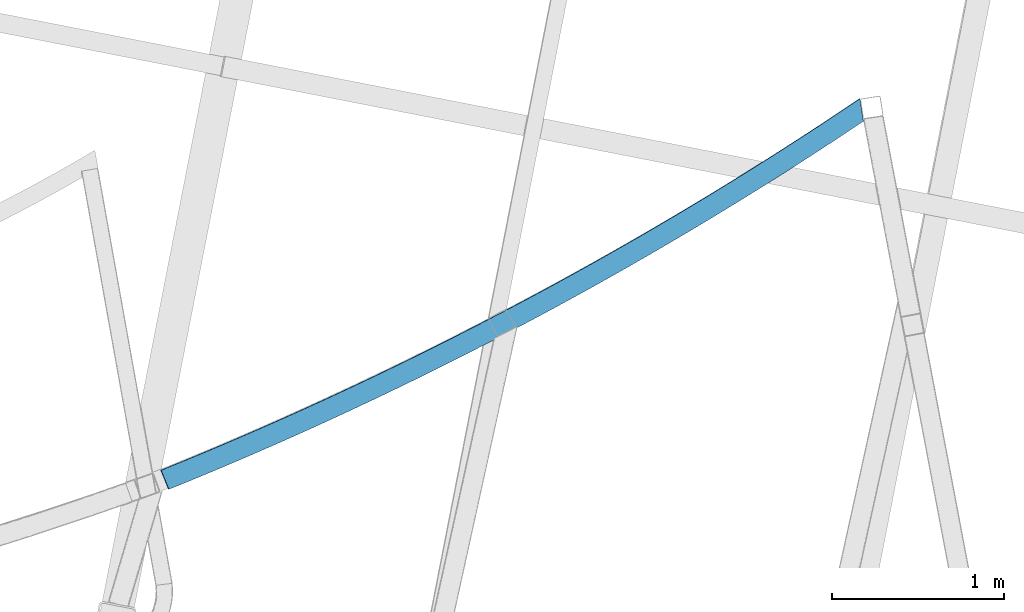
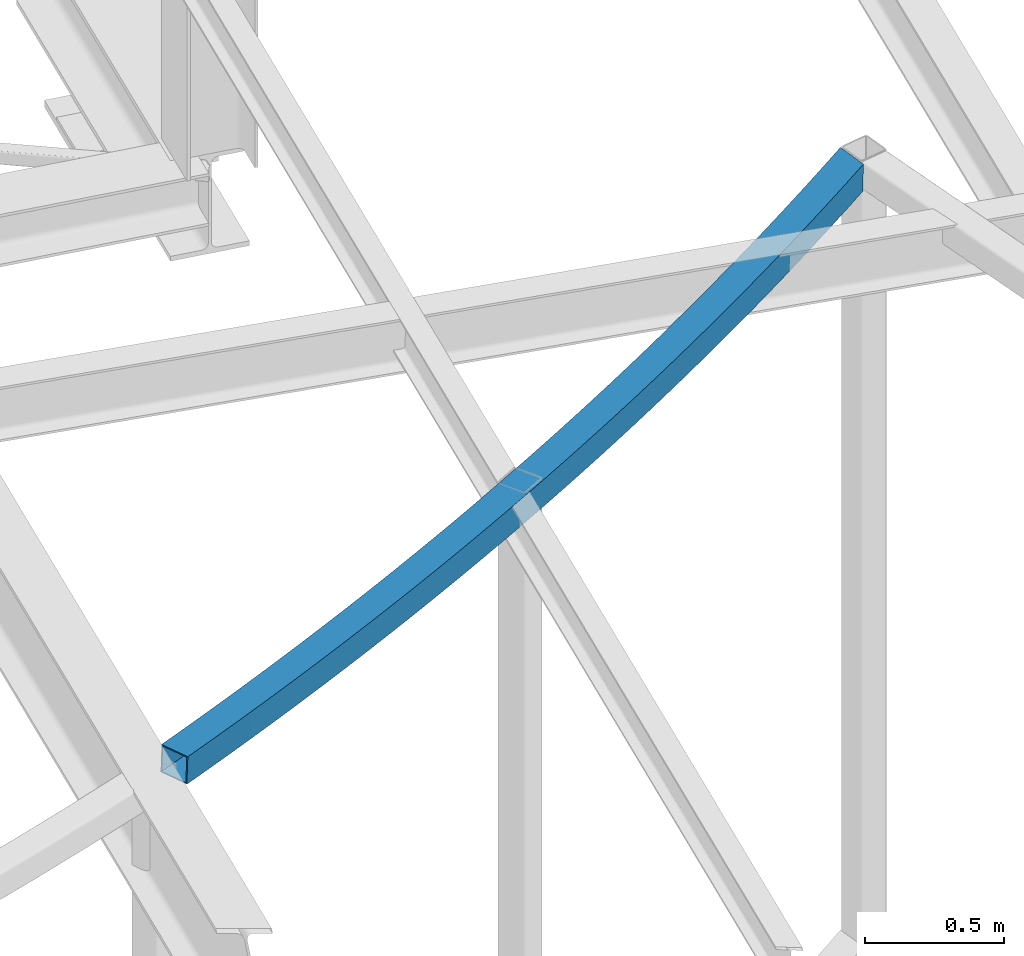
# One storey, part 212 of 215: 1 beam, 1 element without a shape of its own.
"""IFC2X3 building model written with IfcOpenShell, lengths in millimetres."""

from ifc_helpers import new_model, si_unit, frame, origin_with_axes, place, context, subcontext, project, spatial, faceted_brep, material, type_object, element, aggregate, save


model = new_model("IFC2X3")

# Units and contexts
model_context = context("Model", 3, precision=1e-05, world=origin_with_axes())
body_context = subcontext(model_context, "Body", "Model", "MODEL_VIEW")
ifc_project = project(units=[si_unit("LENGTHUNIT", "METRE", prefix="MILLI"), si_unit("AREAUNIT", "SQUARE_METRE"), si_unit("VOLUMEUNIT", "CUBIC_METRE"), si_unit("MASSUNIT", "GRAM", prefix="KILO"), si_unit("TIMEUNIT", "SECOND"), si_unit("PLANEANGLEUNIT", "RADIAN"), si_unit("SOLIDANGLEUNIT", "STERADIAN"), si_unit("THERMODYNAMICTEMPERATUREUNIT", "DEGREE_CELSIUS"), si_unit("LUMINOUSINTENSITYUNIT", "LUMEN")], contexts=[model_context])

# Site, building, storey
site_placement = place(None, origin_with_axes())
site = spatial("IfcSite", under=ifc_project, at=site_placement, CompositionType="ELEMENT")
building_placement = place(site_placement, origin_with_axes())
building = spatial("IfcBuilding", under=site, at=building_placement, Name="Undefined", CompositionType="ELEMENT")
storey_placement = place(building_placement, origin_with_axes())
storey = spatial("IfcBuildingStorey", under=building, at=storey_placement, Name="Undefined", CompositionType="ELEMENT", Elevation=0.0)

# Assembly, beam
assembly_placement = place(storey_placement, origin_with_axes())
assembly = element("IfcElementAssembly", 1, at=assembly_placement, inside=storey, Name="Steel Assembly", AssemblyPlace="NOTDEFINED", PredefinedType="RIGID_FRAME")
ifc_material = material(Name="STEEL/S275JR")
beam_type = type_object("IfcBeamType", PredefinedType="NOTDEFINED")
beam_placement = place(assembly_placement, frame((89084.2595218362, 7630.04217705501, 12133.4647246624), z_axis=(-0.0305735089921345, 0.00490174899873951, -0.999520501743042), x_axis=(-0.882698810596151, -0.469289658785292, 0.0246987029886998)))
beam = element("IfcBeam", 2, at=beam_placement, type_object=beam_type, material=ifc_material, Name="LISSE", context=body_context, shape_type="Brep", body=[
    faceted_brep([(97.9091276255785, 50.236883199359, 60.0), (85.8695654401672, -69.1576264833711, 59.9999999999982), (178.047752296014, -78.2578184337908, 60.0), (189.587251984922, 41.1860593788879, 60.0000000000018), (270.263237470281, -86.9719402849296, 60.0000000000018), (281.302472320996, 32.5192112448422, 59.9999999999982), (362.514403991925, -95.2998392372319, 60.0000000000018), (373.053180434741, 24.2364907678711, 60.0), (454.7996342642, -103.24136926348, 60.0), (464.83776750481, 16.3380431829937, 60.0), (547.117310093032, -110.796391111311, 60.0), (556.654624115778, 8.824006987139, 60.0), (639.465812715542, -117.96477230567, 60.0), (648.502140286437, 1.69451393668714, 60.0000000000018), (731.84352282816, -124.746387151114, 60.0000000000018), (740.378705497918, -5.05031095480081, 60.0000000000018), (824.248820615263, -131.14111673407, 60.0), (832.282708721963, -11.4103494188603, 60.0), (916.680085777465, -137.148848924822, 60.0), (924.212538449312, -17.3854899340804, 60.0000000000018), (1009.13569756008, -142.769478379611, 60.0), (1016.16658271772, -22.9756277281631, 60.0000000000018), (1101.61403478145, -148.002906542344, 60.0), (1108.14322914042, -28.1806647797202, 59.9999999999982), (1194.11347586145, -152.849041646456, 60.0), (1200.14086493429, -33.0005098199617, 60.0000000000018), (1286.63239884999, -157.307798716363, 60.0), (1292.1578769482, -37.4350783343471, 60.0), (1379.1691814552, -161.379099569116, 60.0), (1384.19265169119, -41.4842925640187, 60.0000000000018), (1471.72220107225, -165.062872815659, 60.0), (1476.24357536093, -45.1480815072428, 60.0000000000018), (1564.28983481143, -168.359053862121, 60.0), (1568.30903387189, -48.426380920544, 59.9999999999982), (1656.87045952688, -171.267584910958, 60.0), (1660.3874128836, -51.3191333199211, 60.0), (1749.46245184488, -173.788414961935, 60.0), (1752.47709782921, -53.8262879818358, 60.0), (1842.06418819244, -175.921499813063, 60.0), (1844.57647394339, -55.9478009440791, 60.0000000000018), (1934.67404482566, -177.666802061307, 59.9999999999982), (1936.68392629108, -57.6836350065278, 59.9999999999982), (2027.29039785828, -179.024291103349, 60.0), (2028.7978397955, -59.0337597318794, 60.0000000000018), (2119.91162329014, -179.993943135982, 59.9999999999982), (2120.91659926659, -59.9981514460742, 60.0000000000018), (2212.53609703561, -180.575741156666, 60.0), (2213.03858942937, -60.5767932388117, 59.9999999999982), (2305.16219495214, -180.769674963762, 59.9999999999982), (2305.16219495214, -60.7696749637544, 60.0), (2397.78829286867, -180.575741156674, 60.0), (2397.2858004749, -60.5767932388044, 60.0), (2490.41276661414, -179.993943135974, 60.0000000000018), (2489.40779063766, -59.9981514460887, 60.0), (2583.033992046, -179.024291103342, 60.0000000000018), (2581.52655010877, -59.0337597318794, 60.0), (2675.65034507863, -177.666802061307, 60.0000000000018), (2673.64046361321, -57.683635006535, 60.0), (2768.26020171185, -175.921499813063, 59.9999999999982), (2765.74791596089, -55.9478009440718, 60.0), (2860.86193805939, -173.788414961935, 59.9999999999982), (2857.84729207508, -53.8262879818358, 60.0), (2953.45393037739, -171.267584910958, 60.0), (2949.93697702067, -51.3191333199284, 60.0000000000018), (3046.03455509283, -168.359053862128, 60.0000000000018), (3042.0153560324, -48.426380920544, 60.0), (3138.60218883202, -165.062872815652, 60.0000000000018), (3134.08081454334, -45.1480815072355, 60.0000000000018), (3231.15520844905, -161.379099569116, 60.0000000000018), (3226.13173821309, -41.4842925640187, 60.0), (3323.69199105431, -157.307798716356, 60.0000000000018), (3318.16651295609, -37.4350783343471, 60.0000000000018), (3416.21091404282, -152.849041646448, 60.0000000000018), (3410.18352496999, -33.0005098199617, 60.0000000000018), (3508.71035512284, -148.002906542351, 60.0), (3502.18116076387, -28.1806647797275, 60.0000000000018), (3601.18869234419, -142.769478379611, 60.0), (3594.15780718657, -22.9756277281704, 60.0), (3693.64430412681, -137.14884892483, 60.0), (3686.11185145496, -17.3854899340804, 60.0), (3786.07556928899, -131.14111673407, 59.9999999999982), (3778.04168118231, -11.4103494188603, 60.0), (3878.48086707613, -124.746387151121, 60.0), (3869.94568440638, -5.05031095479353, 60.0), (3970.85857718876, -117.96477230567, 60.0000000000018), (3961.82224961782, 1.69451393669442, 60.0), (4063.20707981123, -110.796391111318, 59.9999999999982), (4053.66976578849, 8.82400698713172, 60.0000000000018), (4155.52475564009, -103.24136926348, 60.0000000000018), (4145.48662239946, 16.3380431829937, 60.0), (4247.80998591236, -95.2998392372247, 59.9999999999982), (4237.27120946955, 24.2364907678711, 60.0000000000018), (4340.06115243399, -86.9719402849296, 60.0), (4329.02191758329, 32.5192112448422, 60.0000000000018), (4432.27663760827, -78.2578184337908, 60.0000000000018), (4420.73713791936, 41.1860593788879, 60.0), (4524.4548244641, -69.1576264833857, 60.0000000000018), (4512.41526227869, 50.2368831993663, 60.0), (4616.59409668444, -59.6715240028207, 60.0000000000018), (4604.05468311266, 59.6715240028134, 59.9999999999982), (4524.45482445264, -69.1576264833784, -59.9999999999982), (4616.59409667297, -59.6715240028207, -60.0), (4432.27663759679, -78.2578184337981, -60.0), (4340.06115242252, -86.9719402849223, -60.0), (4247.80998590087, -95.2998392372319, -59.9999999999982), (4155.52475562862, -103.241369263473, -59.9999999999982), (4063.20707979977, -110.796391111311, -59.9999999999982), (3970.85857717728, -117.964772305662, -59.9999999999982), (3878.48086706466, -124.746387151114, -60.0), (3786.07556927754, -131.141116734056, -60.0000000000018), (3693.64430411533, -137.148848924822, -59.9999999999982), (3601.18869233273, -142.769478379611, -59.9999999999982), (3508.71035511134, -148.002906542359, -59.9999999999982), (3416.21091403136, -152.849041646448, -60.0), (3323.69199104281, -157.307798716363, -60.0), (3231.15520843759, -161.379099569109, -59.9999999999982), (3138.60218882054, -165.062872815659, -60.0), (3046.03455508135, -168.359053862128, -60.0), (2953.45393036591, -171.267584910966, -60.0000000000018), (2860.86193804791, -173.788414961942, -60.0), (2768.26020170037, -175.921499813056, -59.9999999999982), (2675.65034506716, -177.666802061314, -60.0), (2583.03399203453, -179.024291103342, -59.9999999999982), (2490.41276660268, -179.993943135982, -60.0), (2397.78829285719, -180.575741156674, -59.9999999999982), (2305.16219494065, -180.769674963762, -59.9999999999982), (2212.53609702415, -180.575741156674, -59.9999999999982), (2119.91162327865, -179.993943135982, -59.9999999999982), (2027.29039784679, -179.024291103342, -60.0), (1934.67404481418, -177.666802061314, -59.9999999999982), (1842.06418818094, -175.921499813056, -60.0), (1749.4624518334, -173.788414961942, -59.9999999999982), (1656.8704595154, -171.267584910958, -60.0000000000018), (1564.28983479996, -168.359053862128, -59.9999999999982), (1471.72220106077, -165.062872815652, -60.0), (1379.16918144374, -161.379099569109, -60.0), (1286.6323988385, -157.307798716356, -60.0), (1194.11347584998, -152.849041646456, -59.9999999999982), (1101.61403476997, -148.002906542351, -60.0), (1009.13569754861, -142.769478379611, -59.9999999999982), (916.680085765998, -137.148848924822, -60.0), (824.248820603782, -131.14111673407, -59.9999999999982), (731.843522816678, -124.746387151114, -60.0), (639.46581270406, -117.96477230567, -60.0), (547.117310081579, -110.796391111311, -60.0), (454.799634252719, -103.24136926348, -59.9999999999982), (362.514403980444, -95.2998392372319, -59.9999999999982), (270.263237458799, -86.9719402849296, -59.9999999999982), (178.047752284518, -78.2578184337981, -60.0), (85.8695654286857, -69.1576264833784, -60.0), (97.9091276140971, 50.2368831993736, -60.0), (49.7533491996001, -65.439319185054, -59.9999999999982), (6.26970678013458, 59.6715240028134, -60.0), (189.58725197344, 41.1860593788806, -59.9999999999982), (281.302472309515, 32.5192112448349, -59.9999999999982), (373.053180423274, 24.2364907678711, -60.0), (464.837767493329, 16.3380431829937, -59.9999999999982), (556.654624104311, 8.82400698713172, -60.0000000000018), (648.502140274955, 1.69451393669442, -59.9999999999982), (740.378705486422, -5.05031095480808, -60.0), (832.282708710496, -11.4103494188457, -59.9999999999982), (924.212538437845, -17.3854899340804, -60.0), (1016.16658270624, -22.9756277281704, -59.9999999999982), (1108.14322912894, -28.1806647797202, -59.9999999999982), (1200.1408649228, -33.0005098199545, -60.0), (1292.1578769367, -37.4350783343398, -59.9999999999982), (1384.19265167971, -41.4842925640187, -60.0), (1476.24357534945, -45.1480815072428, -59.9999999999982), (1568.30903386041, -48.4263809205368, -60.0), (1660.38741287215, -51.3191333199211, -59.9999999999982), (1752.47709781771, -53.8262879818431, -59.9999999999982), (1844.57647393191, -55.9478009440791, -60.0), (1936.6839262796, -57.6836350065278, -60.0), (2028.79783978403, -59.0337597318721, -59.9999999999982), (2120.91659925513, -59.9981514460815, -60.0), (2213.03858941791, -60.5767932388117, -60.0), (2305.16219494065, -60.7696749637616, -60.0000000000018), (2397.28580046343, -60.5767932388117, -59.9999999999982), (2489.4077906262, -59.9981514460815, -59.9999999999982), (2581.52655009732, -59.0337597318794, -60.0), (2673.64046360171, -57.6836350065278, -60.0000000000018), (2765.74791594941, -55.9478009440791, -60.0), (2857.84729206361, -53.8262879818358, -59.9999999999982), (2949.93697700919, -51.3191333199211, -60.0), (3042.01535602091, -48.426380920544, -60.0), (3134.08081453186, -45.1480815072355, -60.0), (3226.1317382016, -41.484292564026, -59.9999999999982), (3318.1665129446, -37.4350783343398, -60.0), (3410.18352495851, -33.0005098199545, -60.0), (3502.18116075237, -28.180664779713, -60.0), (3594.15780717508, -22.9756277281704, -59.9999999999982), (3686.11185144349, -17.3854899340877, -59.9999999999982), (3778.04168117081, -11.4103494188603, -60.0000000000018), (3869.9456843949, -5.05031095480081, -60.0), (3961.82224960637, 1.69451393669442, -59.9999999999982), (4053.66976577701, 8.82400698713172, -59.9999999999982), (4145.48662238799, 16.338043183001, -59.9999999999982), (4237.27120945805, 24.2364907678711, -60.0), (4329.02191757181, 32.5192112448422, -59.9999999999982), (4420.73713790788, 41.1860593788806, -60.0), (4512.4152622672, 50.2368831993736, -60.0), (4604.05468310116, 59.6715240028134, -60.0), (5.74723122565774, 54.6988970025777, 55.0), (4.2177069560712, 54.8628430973331, 55.0000000000018), (5.7472312211612, 54.698897002585, 7.84636148544087), (5.40627774281893, 51.4538945439344, 55.0), (97.4074792007305, 45.2621119625837, 55.0000000000018), (86.3712138640985, -64.1828552465959, 55.0000000000018), (44.2110295606835, -59.8422975314825, 55.0), (86.3712138535629, -64.1828552465959, -55.0), (47.7736404860043, -60.2090824172483, -55.0), (97.4074791901949, 45.262111962591, -55.0000000000018), (7.78265971245128, 54.4893415887782, -54.9999999999982), (189.106439486888, 36.2092311366869, -55.0), (189.106439497395, 36.2092311366941, 54.9999999999982), (178.528564782566, -73.2809901915971, 55.0000000000018), (178.52856477203, -73.2809901916044, -55.0), (270.723205578062, -81.99314230452, -54.9999999999982), (280.842504191212, 27.5404132644326, -55.0), (280.842504201733, 27.5404132644398, 55.0), (270.723205588598, -81.9931423045127, 55.0), (362.953519676565, -90.3191588203481, 55.0000000000018), (362.953519666029, -90.3191588203481, -54.9999999999982), (372.61406473862, 19.2558103509946, -55.0000000000018), (372.614064749141, 19.2558103509873, 55.0000000000018), (464.419511952627, 11.3555676643882, 54.9999999999982), (455.217889815394, -98.2588937448745, 55.0000000000018), (455.217889804888, -98.2588937448818, -55.0), (464.41951194212, 11.3555676643882, -55.0), (556.257236020509, 3.8398237330257, -55.0), (556.257236031044, 3.8398237330257, 55.0), (547.514698176834, -105.812207857212, 54.9999999999982), (547.514698166327, -105.812207857205, -54.9999999999982), (639.842326353319, -112.978968712239, -55.0), (648.125626626657, -3.2912896567359, -54.9999999999982), (648.125626637178, -3.2912896567359, 55.0000000000018), (639.842326363854, -112.978968712239, 55.0000000000018), (732.19915543891, -119.759050642948, 55.0), (732.199155428389, -119.759050642941, -55.0), (740.023072875658, -10.0376474629884, -54.9999999999982), (740.023072886193, -10.0376474629884, 55.0000000000018), (831.947963383704, -16.3991313903243, 55.0), (824.583565952576, -126.152334762599, 55.0), (824.583565942055, -126.152334762592, -54.9999999999982), (831.947963373197, -16.3991313903316, -54.9999999999982), (923.898686243643, -22.3756298920271, -55.0), (923.898686254164, -22.3756298920271, 55.0), (916.993937971652, -132.158708966868, 55.0), (916.993937961131, -132.158708966883, -55.0), (1009.42865109732, -137.778067935797, -55.0), (1015.87362915848, -27.9670381719698, -55.0), (1015.873629169, -27.967038171977, 55.0000000000018), (1009.42865110784, -137.778067935804, 55.0), (1101.88608454593, -143.010313135572, 55.0000000000018), (1101.88608453539, -143.010313135579, -55.0), (1107.87117936445, -33.1732581864926, -54.9999999999982), (1107.87117937498, -33.1732581864999, 55.0000000000018), (1199.88972372246, -37.9941986460617, 55.0), (1194.36461707235, -147.855352820341, 55.0000000000018), (1194.36461706183, -147.855352820341, -55.0), (1199.88972371192, -37.994198646069, -54.9999999999982), (1291.92764868311, -42.4297750169208, -54.9999999999982), (1291.92764869361, -42.4297750169208, 55.0), (1286.86262710359, -152.313102033782, 55.0), (1286.86262709308, -152.313102033782, -55.0), (1379.37849270405, -156.383482610567, -54.9999999999982), (1383.98334042035, -46.4799095225608, -54.9999999999982), (1383.98334043087, -46.4799095225681, 55.0), (1379.37849271458, -156.383482610567, 54.9999999999982), (1471.91059166714, -160.066423177799, 55.0), (1471.91059165662, -160.066423177799, -55.0), (1476.05518475459, -50.1445311450952, -55.0), (1476.05518476509, -50.144531145088, 55.0), (1568.14156724387, -53.4235756264388, 55.0000000000018), (1564.45730143848, -163.361859156226, 54.9999999999982), (1564.45730142796, -163.361859156219, -54.9999999999982), (1568.14156723335, -53.4235756264388, -55.0000000000018), (1660.24087314942, -56.3169854695443, -55.0), (1660.24087315994, -56.3169854695443, 55.0), (1657.01699924961, -166.269732761328, 55.0), (1657.01699923907, -166.269732761335, -54.9999999999982), (1749.58806208323, -168.789993004437, -54.9999999999982), (1752.35148756884, -58.8247099393484, -54.9999999999982), (1752.35148757936, -58.8247099393484, 55.0000000000018), (1749.58806209375, -168.789993004444, 55.0), (1842.16886676491, -170.922595693519, 55.0), (1842.16886675439, -170.922595693519, -54.9999999999982), (1844.47179535942, -60.9467050636231, -55.0), (1844.47179536996, -60.9467050636158, 55.0000000000018), (1936.60018122954, -62.6829336338196, 55.0000000000018), (1934.75778988622, -172.66750343403, 55.0), (1934.75778987573, -172.66750343403, -55.0), (1936.60018121902, -62.6829336338124, -55.0), (2028.73502970378, -64.0333652056943, -55.0), (2028.7350297143, -64.0333652056943, 55.0), (2027.35320793852, -174.024685629527, 55.0), (2027.353207928, -174.024685629527, -55.0), (2119.95349727815, -174.994118482238, -54.9999999999982), (2120.87472525658, -64.9979760998322, -54.9999999999982), (2120.8747252671, -64.9979760998176, 55.0000000000018), (2119.95349728869, -174.994118482238, 55.0000000000018), (2212.55703421822, -175.575784993431, 55.0000000000018), (2212.55703420768, -175.575784993438, -54.9999999999982), (2213.0176522353, -65.5767494020547, -55.0), (2213.01765224582, -65.5767494020547, 55.0), (2305.16219495166, -65.7696749637689, 55.0000000000018), (2305.16219495166, -175.769674963762, 55.0000000000018), (2305.16219494113, -175.769674963762, -54.9999999999982), (2305.16219494115, -65.7696749637689, -55.0), (2397.30673764698, -65.5767494020474, -54.9999999999982), (2397.30673765751, -65.5767494020547, 55.0000000000018), (2397.76735568509, -175.575784993431, 55.0), (2397.7673556746, -175.575784993431, -55.0), (2490.37089260413, -174.994118482231, -55.0), (2489.4496646257, -64.9979760998176, -54.9999999999982), (2489.44966463621, -64.9979760998249, 55.0), (2490.37089261464, -174.994118482231, 55.0), (2582.97118196479, -174.024685629534, 55.0), (2582.97118195429, -174.024685629527, -55.0), (2581.58936017849, -64.0333652056943, -54.9999999999982), (2581.58936018903, -64.033365205687, 55.0000000000018), (2673.72420867378, -62.6829336338124, 55.0000000000018), (2675.56660001708, -172.66750343403, 54.9999999999982), (2675.56660000657, -172.667503434022, -54.9999999999982), (2673.72420866325, -62.6829336338196, -54.9999999999982), (2765.85259452283, -60.9467050636158, -55.0), (2765.85259453335, -60.9467050636158, 55.0), (2768.15552313841, -170.922595693512, 55.0000000000018), (2768.15552312788, -170.922595693512, -55.0), (2860.73632779905, -168.789993004444, -55.0000000000018), (2857.97290231344, -58.8247099393484, -54.9999999999982), (2857.97290232395, -58.8247099393411, 55.0), (2860.73632780956, -168.789993004437, 55.0000000000018), (2953.30739065372, -166.269732761328, 55.0000000000018), (2953.30739064318, -166.269732761335, -55.0000000000018), (2950.08351673286, -56.3169854695443, -55.0), (2950.08351674338, -56.3169854695516, 54.9999999999982), (3042.18282265945, -53.4235756264461, 55.0000000000018), (3045.86708846485, -163.361859156226, 55.0), (3045.86708845431, -163.361859156226, -55.0), (3042.18282264892, -53.4235756264388, -54.9999999999982), (3134.26920512771, -50.1445311450807, -55.0), (3134.26920513823, -50.144531145088, 55.0000000000018), (3138.41379823619, -160.066423177806, 55.0), (3138.41379822567, -160.066423177799, -54.9999999999982), (3230.94589717823, -156.383482610567, -55.0), (3226.34104946192, -46.4799095225681, -55.0), (3226.34104947245, -46.4799095225681, 55.0), (3230.94589718875, -156.383482610574, 55.0), (3323.46176279974, -152.313102033768, 55.0), (3323.46176278921, -152.313102033782, -55.0), (3318.39674119918, -42.429775016928, -55.0), (3318.39674120971, -42.429775016928, 55.0), (3410.43466618088, -37.994198646069, 55.0000000000018), (3415.95977283097, -147.855352820341, 55.0000000000018), (3415.95977282045, -147.855352820341, -54.9999999999982), (3410.43466617036, -37.9941986460617, -55.0), (3502.45321051784, -33.1732581864926, -55.0), (3502.45321052833, -33.1732581864999, 55.0), (3508.4383053574, -143.010313135586, 54.9999999999982), (3508.43830534689, -143.010313135579, -54.9999999999982), (3600.89573878497, -137.778067935797, -54.9999999999982), (3594.4507607238, -27.967038171977, -54.9999999999982), (3594.45076073433, -27.9670381719698, 55.0), (3600.89573879549, -137.778067935804, 55.0), (3693.33045193166, -132.158708966883, 55.0), (3693.33045192114, -132.158708966883, -54.9999999999982), (3686.42570363861, -22.3756298920271, -55.0), (3686.42570364915, -22.3756298920198, 55.0000000000018), (3778.37642651961, -16.3991313903243, 55.0), (3785.74082395076, -126.152334762599, 55.0000000000018), (3785.74082394024, -126.152334762599, -54.9999999999982), (3778.37642650909, -16.3991313903243, -54.9999999999982), (3870.30131700661, -10.0376474629811, -54.9999999999982), (3870.30131701713, -10.0376474629811, 55.0), (3878.1252344644, -119.759050642941, 54.9999999999982), (3878.1252344539, -119.759050642933, -55.0), (3970.48206352895, -112.978968712239, -55.0), (3962.19876325564, -3.2912896567359, -54.9999999999982), (3962.19876326616, -3.29128965672862, 55.0000000000018), (3970.48206353947, -112.978968712239, 55.0), (4062.80969172648, -105.812207857212, 55.0000000000018), (4062.80969171596, -105.812207857212, -55.0), (4054.06715386179, 3.83982373303297, -54.9999999999982), (4054.0671538723, 3.8398237330257, 55.0000000000018), (4145.90487795068, 11.3555676643882, 55.0000000000018), (4155.10650008792, -98.2588937448672, 55.0000000000018), (4155.10650007741, -98.2588937448745, -54.9999999999982), (4145.90487794018, 11.3555676643955, -54.9999999999982), (4237.71032514365, 19.2558103509946, -55.0), (4237.71032515417, 19.2558103509873, 55.0000000000018), (4247.37087022676, -90.3191588203481, 55.0), (4247.37087021624, -90.3191588203481, -55.0), (4339.60118430422, -81.9931423045273, -54.9999999999982), (4329.48188569107, 27.5404132644398, -54.9999999999982), (4329.48188570158, 27.5404132644398, 54.9999999999982), (4339.60118431476, -81.9931423045273, 55.0000000000018), (4431.79582512076, -73.2809901916116, 55.0000000000018), (4431.79582511025, -73.2809901916044, -54.9999999999982), (4421.2179503954, 36.2092311366796, -54.9999999999982), (4421.21795040593, 36.2092311366869, 55.0000000000018), (4512.91691070261, 45.262111962591, 55.0000000000018), (4523.95317603924, -64.1828552465959, 55.0), (4523.95317602872, -64.1828552465959, -54.9999999999982), (4512.91691069207, 45.262111962591, -55.0), (4604.57715866715, 54.6988970025704, -55.0), (4604.57715867765, 54.6988970025777, 55.0), (4616.07162111846, -54.698897002585, 55.0000000000018), (4616.07162110793, -54.6988970025923, -55.0), (6.26970679161604, 59.6715240028207, 60.0000000000018), (2.23416131200793, 60.1040845935495, 60.0), (5.37012427841546, 51.1098063080062, 60.0000000000018), (45.8668645537837, -65.0391902187621, 60.0)], [[[0, 1, 2, 3]], [[3, 2, 4, 5]], [[5, 4, 6, 7]], [[7, 6, 8, 9]], [[9, 8, 10, 11]], [[11, 10, 12, 13]], [[13, 12, 14, 15]], [[15, 14, 16, 17]], [[17, 16, 18, 19]], [[19, 18, 20, 21]], [[21, 20, 22, 23]], [[23, 22, 24, 25]], [[25, 24, 26, 27]], [[27, 26, 28, 29]], [[29, 28, 30, 31]], [[31, 30, 32, 33]], [[33, 32, 34, 35]], [[35, 34, 36, 37]], [[37, 36, 38, 39]], [[39, 38, 40, 41]], [[41, 40, 42, 43]], [[43, 42, 44, 45]], [[45, 44, 46, 47]], [[47, 46, 48, 49]], [[49, 48, 50, 51]], [[51, 50, 52, 53]], [[53, 52, 54, 55]], [[55, 54, 56, 57]], [[57, 56, 58, 59]], [[59, 58, 60, 61]], [[61, 60, 62, 63]], [[63, 62, 64, 65]], [[65, 64, 66, 67]], [[67, 66, 68, 69]], [[69, 68, 70, 71]], [[71, 70, 72, 73]], [[73, 72, 74, 75]], [[75, 74, 76, 77]], [[77, 76, 78, 79]], [[79, 78, 80, 81]], [[81, 80, 82, 83]], [[83, 82, 84, 85]], [[85, 84, 86, 87]], [[87, 86, 88, 89]], [[89, 88, 90, 91]], [[91, 90, 92, 93]], [[93, 92, 94, 95]], [[95, 94, 96, 97]], [[97, 96, 98, 99]], [[96, 100, 101, 98]], [[94, 102, 100, 96]], [[92, 103, 102, 94]], [[90, 104, 103, 92]], [[88, 105, 104, 90]], [[86, 106, 105, 88]], [[84, 107, 106, 86]], [[82, 108, 107, 84]], [[80, 109, 108, 82]], [[78, 110, 109, 80]], [[76, 111, 110, 78]], [[74, 112, 111, 76]], [[72, 113, 112, 74]], [[70, 114, 113, 72]], [[68, 115, 114, 70]], [[66, 116, 115, 68]], [[64, 117, 116, 66]], [[62, 118, 117, 64]], [[60, 119, 118, 62]], [[58, 120, 119, 60]], [[56, 121, 120, 58]], [[54, 122, 121, 56]], [[52, 123, 122, 54]], [[50, 124, 123, 52]], [[48, 125, 124, 50]], [[46, 126, 125, 48]], [[44, 127, 126, 46]], [[42, 128, 127, 44]], [[40, 129, 128, 42]], [[38, 130, 129, 40]], [[36, 131, 130, 38]], [[34, 132, 131, 36]], [[32, 133, 132, 34]], [[30, 134, 133, 32]], [[28, 135, 134, 30]], [[26, 136, 135, 28]], [[24, 137, 136, 26]], [[22, 138, 137, 24]], [[20, 139, 138, 22]], [[18, 140, 139, 20]], [[16, 141, 140, 18]], [[14, 142, 141, 16]], [[12, 143, 142, 14]], [[10, 144, 143, 12]], [[8, 145, 144, 10]], [[6, 146, 145, 8]], [[4, 147, 146, 6]], [[2, 148, 147, 4]], [[1, 149, 148, 2]], [[150, 149, 151, 152]], [[149, 150, 153, 148]], [[148, 153, 154, 147]], [[147, 154, 155, 146]], [[146, 155, 156, 145]], [[145, 156, 157, 144]], [[144, 157, 158, 143]], [[143, 158, 159, 142]], [[142, 159, 160, 141]], [[141, 160, 161, 140]], [[140, 161, 162, 139]], [[139, 162, 163, 138]], [[138, 163, 164, 137]], [[137, 164, 165, 136]], [[136, 165, 166, 135]], [[135, 166, 167, 134]], [[134, 167, 168, 133]], [[133, 168, 169, 132]], [[132, 169, 170, 131]], [[131, 170, 171, 130]], [[130, 171, 172, 129]], [[129, 172, 173, 128]], [[128, 173, 174, 127]], [[127, 174, 175, 126]], [[126, 175, 176, 125]], [[125, 176, 177, 124]], [[124, 177, 178, 123]], [[123, 178, 179, 122]], [[122, 179, 180, 121]], [[121, 180, 181, 120]], [[120, 181, 182, 119]], [[119, 182, 183, 118]], [[118, 183, 184, 117]], [[117, 184, 185, 116]], [[116, 185, 186, 115]], [[115, 186, 187, 114]], [[114, 187, 188, 113]], [[113, 188, 189, 112]], [[112, 189, 190, 111]], [[111, 190, 191, 110]], [[110, 191, 192, 109]], [[109, 192, 193, 108]], [[108, 193, 194, 107]], [[107, 194, 195, 106]], [[106, 195, 196, 105]], [[105, 196, 197, 104]], [[104, 197, 198, 103]], [[103, 198, 199, 102]], [[102, 199, 200, 100]], [[100, 200, 201, 101]], [[202, 203, 204]], [[202, 205, 203]], [[202, 206, 207, 208, 205]], [[207, 209, 210, 208]], [[209, 211, 212, 210]], [[204, 203, 205, 208, 210, 212]], [[211, 206, 202, 204, 212]], [[206, 211, 213, 214]], [[207, 206, 214, 215]], [[209, 207, 215, 216]], [[211, 209, 216, 213]], [[213, 216, 217, 218]], [[214, 213, 218, 219]], [[215, 214, 219, 220]], [[216, 215, 220, 217]], [[217, 220, 221, 222]], [[218, 217, 222, 223]], [[219, 218, 223, 224]], [[220, 219, 224, 221]], [[221, 224, 225, 226]], [[222, 221, 226, 227]], [[223, 222, 227, 228]], [[224, 223, 228, 225]], [[225, 228, 229, 230]], [[226, 225, 230, 231]], [[227, 226, 231, 232]], [[228, 227, 232, 229]], [[229, 232, 233, 234]], [[230, 229, 234, 235]], [[231, 230, 235, 236]], [[232, 231, 236, 233]], [[233, 236, 237, 238]], [[234, 233, 238, 239]], [[235, 234, 239, 240]], [[236, 235, 240, 237]], [[237, 240, 241, 242]], [[238, 237, 242, 243]], [[239, 238, 243, 244]], [[240, 239, 244, 241]], [[241, 244, 245, 246]], [[242, 241, 246, 247]], [[243, 242, 247, 248]], [[244, 243, 248, 245]], [[245, 248, 249, 250]], [[246, 245, 250, 251]], [[247, 246, 251, 252]], [[248, 247, 252, 249]], [[249, 252, 253, 254]], [[250, 249, 254, 255]], [[251, 250, 255, 256]], [[252, 251, 256, 253]], [[253, 256, 257, 258]], [[254, 253, 258, 259]], [[255, 254, 259, 260]], [[256, 255, 260, 257]], [[257, 260, 261, 262]], [[258, 257, 262, 263]], [[259, 258, 263, 264]], [[260, 259, 264, 261]], [[261, 264, 265, 266]], [[262, 261, 266, 267]], [[263, 262, 267, 268]], [[264, 263, 268, 265]], [[265, 268, 269, 270]], [[266, 265, 270, 271]], [[267, 266, 271, 272]], [[268, 267, 272, 269]], [[269, 272, 273, 274]], [[270, 269, 274, 275]], [[271, 270, 275, 276]], [[272, 271, 276, 273]], [[273, 276, 277, 278]], [[274, 273, 278, 279]], [[275, 274, 279, 280]], [[276, 275, 280, 277]], [[277, 280, 281, 282]], [[278, 277, 282, 283]], [[279, 278, 283, 284]], [[280, 279, 284, 281]], [[281, 284, 285, 286]], [[282, 281, 286, 287]], [[283, 282, 287, 288]], [[284, 283, 288, 285]], [[285, 288, 289, 290]], [[286, 285, 290, 291]], [[287, 286, 291, 292]], [[288, 287, 292, 289]], [[289, 292, 293, 294]], [[290, 289, 294, 295]], [[291, 290, 295, 296]], [[292, 291, 296, 293]], [[293, 296, 297, 298]], [[294, 293, 298, 299]], [[295, 294, 299, 300]], [[296, 295, 300, 297]], [[297, 300, 301, 302]], [[298, 297, 302, 303]], [[299, 298, 303, 304]], [[300, 299, 304, 301]], [[301, 304, 305, 306]], [[302, 301, 306, 307]], [[303, 302, 307, 308]], [[304, 303, 308, 305]], [[305, 308, 309, 310]], [[306, 305, 310, 311]], [[307, 306, 311, 312]], [[308, 307, 312, 309]], [[309, 312, 313, 314]], [[310, 309, 314, 315]], [[311, 310, 315, 316]], [[312, 311, 316, 313]], [[313, 316, 317, 318]], [[314, 313, 318, 319]], [[315, 314, 319, 320]], [[316, 315, 320, 317]], [[317, 320, 321, 322]], [[318, 317, 322, 323]], [[319, 318, 323, 324]], [[320, 319, 324, 321]], [[321, 324, 325, 326]], [[322, 321, 326, 327]], [[323, 322, 327, 328]], [[324, 323, 328, 325]], [[325, 328, 329, 330]], [[326, 325, 330, 331]], [[327, 326, 331, 332]], [[328, 327, 332, 329]], [[329, 332, 333, 334]], [[330, 329, 334, 335]], [[331, 330, 335, 336]], [[332, 331, 336, 333]], [[333, 336, 337, 338]], [[334, 333, 338, 339]], [[335, 334, 339, 340]], [[336, 335, 340, 337]], [[337, 340, 341, 342]], [[338, 337, 342, 343]], [[339, 338, 343, 344]], [[340, 339, 344, 341]], [[341, 344, 345, 346]], [[342, 341, 346, 347]], [[343, 342, 347, 348]], [[344, 343, 348, 345]], [[345, 348, 349, 350]], [[346, 345, 350, 351]], [[347, 346, 351, 352]], [[348, 347, 352, 349]], [[349, 352, 353, 354]], [[350, 349, 354, 355]], [[351, 350, 355, 356]], [[352, 351, 356, 353]], [[353, 356, 357, 358]], [[354, 353, 358, 359]], [[355, 354, 359, 360]], [[356, 355, 360, 357]], [[357, 360, 361, 362]], [[358, 357, 362, 363]], [[359, 358, 363, 364]], [[360, 359, 364, 361]], [[361, 364, 365, 366]], [[362, 361, 366, 367]], [[363, 362, 367, 368]], [[364, 363, 368, 365]], [[365, 368, 369, 370]], [[366, 365, 370, 371]], [[367, 366, 371, 372]], [[368, 367, 372, 369]], [[369, 372, 373, 374]], [[370, 369, 374, 375]], [[371, 370, 375, 376]], [[372, 371, 376, 373]], [[373, 376, 377, 378]], [[374, 373, 378, 379]], [[375, 374, 379, 380]], [[376, 375, 380, 377]], [[377, 380, 381, 382]], [[378, 377, 382, 383]], [[379, 378, 383, 384]], [[380, 379, 384, 381]], [[381, 384, 385, 386]], [[382, 381, 386, 387]], [[383, 382, 387, 388]], [[384, 383, 388, 385]], [[385, 388, 389, 390]], [[386, 385, 390, 391]], [[387, 386, 391, 392]], [[388, 387, 392, 389]], [[389, 392, 393, 394]], [[390, 389, 394, 395]], [[391, 390, 395, 396]], [[392, 391, 396, 393]], [[393, 396, 397, 398]], [[394, 393, 398, 399]], [[395, 394, 399, 400]], [[396, 395, 400, 397]], [[397, 400, 401, 402]], [[398, 397, 402, 403]], [[399, 398, 403, 404]], [[400, 399, 404, 401]], [[401, 404, 405, 406]], [[402, 401, 406, 407]], [[403, 402, 407, 408]], [[404, 403, 408, 405]], [[98, 101, 201, 99], [407, 406, 405, 408]], [[200, 97, 99, 201]], [[199, 95, 97, 200]], [[198, 93, 95, 199]], [[197, 91, 93, 198]], [[196, 89, 91, 197]], [[195, 87, 89, 196]], [[194, 85, 87, 195]], [[193, 83, 85, 194]], [[192, 81, 83, 193]], [[191, 79, 81, 192]], [[190, 77, 79, 191]], [[189, 75, 77, 190]], [[188, 73, 75, 189]], [[187, 71, 73, 188]], [[186, 69, 71, 187]], [[185, 67, 69, 186]], [[184, 65, 67, 185]], [[183, 63, 65, 184]], [[182, 61, 63, 183]], [[181, 59, 61, 182]], [[180, 57, 59, 181]], [[179, 55, 57, 180]], [[178, 53, 55, 179]], [[177, 51, 53, 178]], [[176, 49, 51, 177]], [[175, 47, 49, 176]], [[174, 45, 47, 175]], [[173, 43, 45, 174]], [[172, 41, 43, 173]], [[171, 39, 41, 172]], [[170, 37, 39, 171]], [[169, 35, 37, 170]], [[168, 33, 35, 169]], [[167, 31, 33, 168]], [[166, 29, 31, 167]], [[165, 27, 29, 166]], [[164, 25, 27, 165]], [[163, 23, 25, 164]], [[162, 21, 23, 163]], [[161, 19, 21, 162]], [[160, 17, 19, 161]], [[159, 15, 17, 160]], [[158, 13, 15, 159]], [[157, 11, 13, 158]], [[156, 9, 11, 157]], [[155, 7, 9, 156]], [[154, 5, 7, 155]], [[153, 3, 5, 154]], [[150, 0, 3, 153]], [[152, 409, 0, 150]], [[409, 152, 410]], [[409, 410, 411]], [[1, 0, 409, 411, 412]], [[149, 1, 412, 151]], [[411, 410, 152, 151, 412]]]),
])
aggregate(assembly, [beam])

save(model, "model.ifc")
